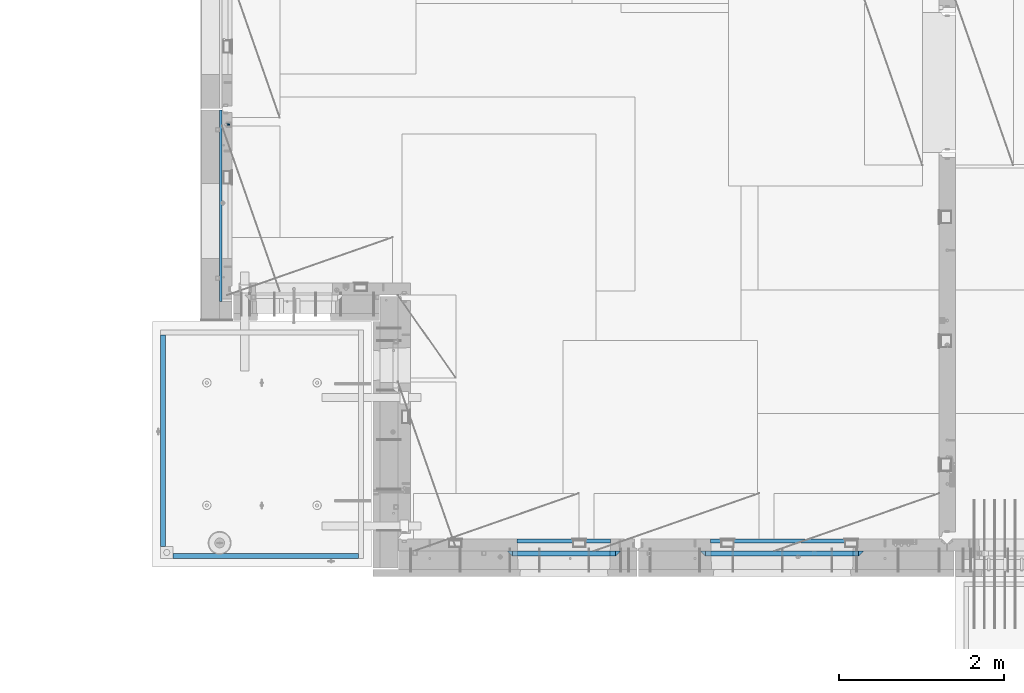
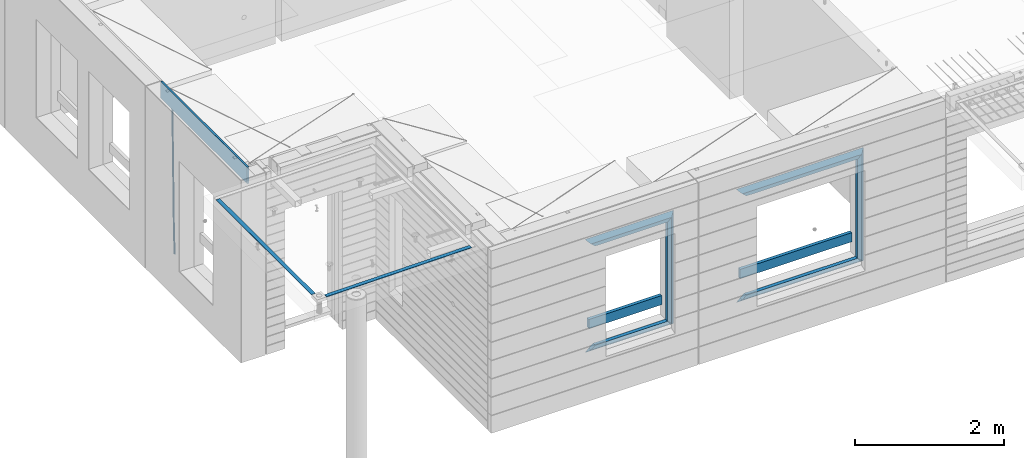
# One storey, part 92 of 349: 18 beams, 4 elements without a shape of their own.
"""IFC2X3 building model written with IfcOpenShell, lengths in millimetres."""

from ifc_helpers import new_model, si_unit, frame, origin_with_axes, place, context, subcontext, project, spatial, faceted_brep, material, type_object, element, aggregate, save


model = new_model("IFC2X3")

# Units and contexts
model_context = context("Model", 3, precision=1e-05, world=origin_with_axes())
body_context = subcontext(model_context, "Body", "Model", "MODEL_VIEW")
ifc_project = project(units=[si_unit("LENGTHUNIT", "METRE", prefix="MILLI"), si_unit("AREAUNIT", "SQUARE_METRE"), si_unit("VOLUMEUNIT", "CUBIC_METRE"), si_unit("MASSUNIT", "GRAM", prefix="KILO"), si_unit("TIMEUNIT", "SECOND"), si_unit("PLANEANGLEUNIT", "RADIAN"), si_unit("SOLIDANGLEUNIT", "STERADIAN"), si_unit("THERMODYNAMICTEMPERATUREUNIT", "DEGREE_CELSIUS"), si_unit("LUMINOUSINTENSITYUNIT", "LUMEN")], contexts=[model_context])

# Site, building, storey
site_placement = place(None, origin_with_axes())
site = spatial("IfcSite", under=ifc_project, at=site_placement, CompositionType="ELEMENT")
building_placement = place(site_placement, origin_with_axes())
building = spatial("IfcBuilding", under=site, at=building_placement, CompositionType="ELEMENT")
storey_placement = place(building_placement, origin_with_axes())
storey = spatial("IfcBuildingStorey", under=building, at=storey_placement, Name="4", CompositionType="ELEMENT", Elevation=0.0)

# Assembly, beam
assembly_1_placement = place(storey_placement, origin_with_axes())
assembly_1 = element("IfcElementAssembly", 1, at=assembly_1_placement, inside=storey, AssemblyPlace="NOTDEFINED", PredefinedType="REINFORCEMENT_UNIT")
ifc_material_1 = material()
beam_type_1 = type_object("IfcBeamType", Name="D20", PredefinedType="NOTDEFINED")
beam_1_placement = place(assembly_1_placement, frame((7964.99972837123, 13015.0021274634, 90990.0), z_axis=(-0.999642804636942, -0.000205726999925762, -0.0267249099902983), x_axis=(-0.0267249099948371, 4.30000201934385e-08, 0.999642825806181)))
beam_1 = element("IfcBeam", 2, at=beam_1_placement, type_object=beam_type_1, material=ifc_material_1, Name="JM20", ObjectType="D20", context=body_context, shape_type="Brep", body=[
    faceted_brep([(0.0, -10.0, 0.0), (-4.19531716033816e-08, -7.07106781186667, -7.07106781187031), (60.4266690400545, -7.0710677960451, -7.07106780570757), (60.4266690441291, -9.99999998418934, 6.15546014159918e-09), (0.0, 0.0, -10.0), (60.426669036824, 1.58106558956206e-08, -9.99999999384454), (4.196772351861e-08, 7.07106781186303, -7.07106781186667), (60.4266690363438, 7.07106782768096, -7.07106780570757), (0.0, 10.0, 0.0), (60.4266690388904, 10.0000000158179, 6.15182216279209e-09), (4.196772351861e-08, 7.07106781185939, 7.07106781185939), (60.4266690429649, 7.07106782768096, 7.07106781802577), (0.0, 0.0, 10.0), (60.4266690461809, 1.58179318532348e-08, 10.0000000061555), (-4.19531716033816e-08, -7.07106781187031, 7.07106781185939), (60.4266690466611, -7.07106779605238, 7.07106781802213), (61.0378400410118, -7.07106779588503, -7.07106780564936), (60.991799419251, -9.99999998403655, 6.21366780251265e-09), (61.0569027789461, 1.5985278878361e-08, -9.99999999378269), (61.0378209396877, 7.07106782784831, -7.07106780564936), (60.9917724058905, 10.0000000159635, 6.21366780251265e-09), (60.9457317841297, 7.07106782781193, 7.0710678180767), (60.9266690461809, 1.59488990902901e-08, 10.0000000062028), (60.9457508854539, -7.07106779591413, 7.0710678180767), (61.6489592143771, -7.07106614513759, -7.06310863441468), (61.5568818710308, -9.9999984576425, 0.00735959856683621), (61.6870830769039, 1.71821739058942e-06, -9.99179257185824), (61.6489210170112, 7.07106947854481, -7.06310888312146), (61.556827851804, 10.0000015422847, 0.00735924683976918), (61.4647505084577, 7.07106922979438, 7.07782747982128), (61.4266266459163, 1.36643211590126e-06, 10.0065114172685), (61.464788705809, -7.07106639389531, 7.07782772852806), (176.543135720174, -7.07075579406956, -5.56673531796696), (176.451058376813, -9.99968810657447, 1.50373291501455), (176.581259582701, 0.000312069292704109, -8.49541925541052), (176.543097522794, 7.07137982961285, -5.56673556667374), (176.451004357587, 10.00031189336, 1.50373256329476), (176.35892701424, 7.07137958085514, 8.57420079627263), (176.320803151699, 0.000311717507429421, 11.5028847337162), (176.358965211621, -7.07075604281999, 8.57420104497578), (177.098753836006, -7.07075429323595, -5.55949898843028), (176.98362511232, -9.99968666800123, 1.510669025065), (177.146421932586, 0.000313595905026887, -8.48805862247536), (177.098706077581, 7.07138133041735, -5.55949936166144), (176.983557571715, 10.0003133318824, 1.51066849724157), (176.868428848029, 7.07138095712435, 8.58083651073321), (176.820760751449, 0.000313067976094317, 11.5093961447819), (176.868476606425, -7.07075466652896, 8.58083688396073), (177.654312950661, -7.07075204110879, -5.54863964998367), (177.516135294456, -9.99968450931192, 1.52107783331303), (177.711524267797, 0.000315886711177882, -8.47701274570863), (177.654255632195, 7.07138358250813, -5.54864021007961), (177.516054233929, 10.0003154905207, 1.5210770412159), (177.377876577739, 7.0713830223176, 8.59079452451624), (177.320665260588, 0.000315094497636892, 11.5191676202448), (177.377933896176, -7.07075260129932, 8.59079508461218), (299.436796249574, -7.07025836271714, -3.1681962331204), (299.298618593355, -9.99919083092027, 3.90152125031091), (299.494007566798, 0.000809565110102994, -6.09656932889993), (299.436738931283, 7.07187726089978, -3.16819679320906), (299.298537533061, 10.0008091689197, 3.90152045822106), (299.160359876842, 7.07187670072017, 10.9712379416487), (299.103148559603, 0.000808772889286047, 13.8996110374392), (299.160417195119, -7.07025892290039, 10.9712385017483), (299.98743051647, -7.07025613056248, -3.15743315966392), (299.971788958996, -9.99918809853989, 3.91467979818117), (299.993912075952, 0.000811591617093654, -6.08679785393178), (299.987423933868, 7.07187949325817, -3.1574327280432), (299.971753863239, 10.0008119014747, 3.91467990454839), (299.95611230444, 7.07187992653053, 10.9867922621015), (299.949630744944, 0.000812204350950196, 13.9161569563694), (299.956118887014, -7.07025569729012, 10.9867918304735), (300.538107039494, -7.07025785017686, -3.16575821840888), (300.644985195438, -9.99919020432935, 3.90450175465594), (300.493854948218, 0.000810030429420294, -6.09435592770024), (300.538151196495, 7.071877773491, -3.16575855385963), (300.645047642858, 10.0008097955724, 3.90450128024895), (300.751925798773, 7.07187744142357, 10.9747612533101), (300.796177890064, 0.000809560813650023, 13.9033589625978), (300.751881641787, -7.07025818224065, 10.9747615887682), (2293.36490490142, -7.07648090940347, -33.2930642912361), (2293.47178305736, -10.0054132635523, -26.2228043181785), (2293.32065281013, -0.00541302880083094, -36.2216620005347), (2293.36494905842, 7.06565471425711, -33.2930646266868), (2293.47184550477, 9.99458673634581, -26.2228047925819), (2293.57872366071, 7.06565438219332, -19.1525448195243), (2293.62297575199, -0.00541349841296324, -16.2239471102366), (2293.57867950371, -7.0764812414709, -19.1525444840736), (2294.0658245362, -7.07648309818615, -33.3036607065333), (2294.05312277409, -10.0054150789219, -26.2315929392535), (2294.10928714235, -0.00541549149056664, -36.2335844756526), (2294.15805078732, 7.06565223761572, -33.3050546393533), (2294.18355038921, 9.99458451388637, -26.2335642579346), (2294.17084862708, 7.06565253314329, -19.1614964906439), (2294.12738602093, -0.00541507354500936, -16.2315727215355), (2294.07862237596, -7.07648280265857, -19.1601025578348), (2294.76670261032, -7.08562269121467, -33.294332712383), (2294.63442802057, -10.0129954178956, -26.2238563411993), (2294.89787471293, -0.0156988342423574, -36.2230891548279), (2294.95110548967, 7.05531064255774, -33.2944998654275), (2294.89521307347, 9.98530428734011, -26.2240927312887), (2294.76293848372, 7.0579315606592, -19.1536163601049), (2294.63176638114, -0.0119922963167483, -16.2248599176673), (2294.57853560438, -7.08300177311321, -19.1534492070678), (2316.52657204497, -7.36937582653991, -33.0047303660212), (2316.39429745522, -10.2967485532172, -25.9342539948302), (2316.65774414754, -0.299451969567599, -35.9334868084661), (2316.7109749243, 6.7715575072325, -33.0048975190657), (2316.65508250811, 9.70155115201487, -25.9344903849269), (2316.52280791836, 6.7741784253376, -18.8640140137468), (2316.39163581574, -0.295745431634714, -15.9352575713092), (2316.33840503903, -7.36675490843481, -18.863846860706), (2317.16202064224, -7.37766220584308, -32.9962731735213), (2317.05438744847, -10.3053562613532, -25.9254688497131), (2317.23607125619, -0.306993473008333, -35.925789846493), (2317.23316144495, 6.76474808850253, -32.9979477328052), (2317.15499573652, 9.6950321815566, -25.9278370341635), (2317.04736254275, 6.7673381260538, -18.8570327103698), (2316.97331192881, -0.303330606784584, -15.9275160373909), (2316.97622174003, -7.37507216829545, -18.8553581510787), (2317.79752306276, -7.37578610372293, -32.9880110666527), (2317.71453320107, -10.3033876998124, -25.9168792378296), (2317.81444760226, -0.305295583297266, -35.918287695793), (2317.75539265381, 6.76628640723357, -32.9911928173897), (2317.65495180529, 9.69652304524061, -25.9213789128698), (2317.5719619436, 6.76892144914746, -18.8502470840467), (2317.55503740412, -0.301569071270933, -15.9199704549137), (2317.61409235255, -7.3731510618054, -18.847065333317), (2417.8183084176, -7.07752398473531, -31.6906369377139), (2417.73531855589, -10.0051255808248, -24.6195051088798), (2417.83523295709, -0.007033464313281, -34.6209135668432), (2417.77617800863, 7.06454852621755, -31.6938186884508), (2417.67573716014, 9.99478516423187, -24.6240047839383), (2417.59274729842, 7.06718356813872, -17.5528729551006), (2417.57582275895, -0.00330695228694822, -14.6225963259749), (2417.6348777074, -7.07488894281778, -17.5496912043673)], [[[0, 1, 2, 3]], [[1, 4, 5, 2]], [[4, 6, 7, 5]], [[6, 8, 9, 7]], [[8, 10, 11, 9]], [[10, 12, 13, 11]], [[12, 14, 15, 13]], [[14, 0, 3, 15]], [[14, 12, 10, 8, 6, 4, 1, 0]], [[3, 2, 16, 17]], [[2, 5, 18, 16]], [[5, 7, 19, 18]], [[7, 9, 20, 19]], [[9, 11, 21, 20]], [[11, 13, 22, 21]], [[13, 15, 23, 22]], [[15, 3, 17, 23]], [[17, 16, 24, 25]], [[16, 18, 26, 24]], [[18, 19, 27, 26]], [[19, 20, 28, 27]], [[20, 21, 29, 28]], [[21, 22, 30, 29]], [[22, 23, 31, 30]], [[23, 17, 25, 31]], [[25, 24, 32, 33]], [[24, 26, 34, 32]], [[26, 27, 35, 34]], [[27, 28, 36, 35]], [[28, 29, 37, 36]], [[29, 30, 38, 37]], [[30, 31, 39, 38]], [[31, 25, 33, 39]], [[33, 32, 40, 41]], [[32, 34, 42, 40]], [[34, 35, 43, 42]], [[35, 36, 44, 43]], [[36, 37, 45, 44]], [[37, 38, 46, 45]], [[38, 39, 47, 46]], [[39, 33, 41, 47]], [[41, 40, 48, 49]], [[40, 42, 50, 48]], [[42, 43, 51, 50]], [[43, 44, 52, 51]], [[44, 45, 53, 52]], [[45, 46, 54, 53]], [[46, 47, 55, 54]], [[47, 41, 49, 55]], [[49, 48, 56, 57]], [[48, 50, 58, 56]], [[50, 51, 59, 58]], [[51, 52, 60, 59]], [[52, 53, 61, 60]], [[53, 54, 62, 61]], [[54, 55, 63, 62]], [[55, 49, 57, 63]], [[57, 56, 64, 65]], [[56, 58, 66, 64]], [[58, 59, 67, 66]], [[59, 60, 68, 67]], [[60, 61, 69, 68]], [[61, 62, 70, 69]], [[62, 63, 71, 70]], [[63, 57, 65, 71]], [[65, 64, 72, 73]], [[64, 66, 74, 72]], [[66, 67, 75, 74]], [[67, 68, 76, 75]], [[68, 69, 77, 76]], [[69, 70, 78, 77]], [[70, 71, 79, 78]], [[71, 65, 73, 79]], [[73, 72, 80, 81]], [[72, 74, 82, 80]], [[74, 75, 83, 82]], [[75, 76, 84, 83]], [[76, 77, 85, 84]], [[77, 78, 86, 85]], [[78, 79, 87, 86]], [[79, 73, 81, 87]], [[81, 80, 88, 89]], [[80, 82, 90, 88]], [[82, 83, 91, 90]], [[83, 84, 92, 91]], [[84, 85, 93, 92]], [[85, 86, 94, 93]], [[86, 87, 95, 94]], [[87, 81, 89, 95]], [[89, 88, 96, 97]], [[88, 90, 98, 96]], [[90, 91, 99, 98]], [[91, 92, 100, 99]], [[92, 93, 101, 100]], [[93, 94, 102, 101]], [[94, 95, 103, 102]], [[95, 89, 97, 103]], [[97, 96, 104, 105]], [[96, 98, 106, 104]], [[98, 99, 107, 106]], [[99, 100, 108, 107]], [[100, 101, 109, 108]], [[101, 102, 110, 109]], [[102, 103, 111, 110]], [[103, 97, 105, 111]], [[105, 104, 112, 113]], [[104, 106, 114, 112]], [[106, 107, 115, 114]], [[107, 108, 116, 115]], [[108, 109, 117, 116]], [[109, 110, 118, 117]], [[110, 111, 119, 118]], [[111, 105, 113, 119]], [[113, 112, 120, 121]], [[112, 114, 122, 120]], [[114, 115, 123, 122]], [[115, 116, 124, 123]], [[116, 117, 125, 124]], [[117, 118, 126, 125]], [[118, 119, 127, 126]], [[119, 113, 121, 127]], [[121, 120, 128, 129]], [[120, 122, 130, 128]], [[122, 123, 131, 130]], [[123, 124, 132, 131]], [[124, 125, 133, 132]], [[125, 126, 134, 133]], [[126, 127, 135, 134]], [[127, 121, 129, 135]], [[130, 131, 132, 133, 134, 135, 129, 128]]]),
])

assembly_2_placement = place(storey_placement, origin_with_axes())
assembly_2 = element("IfcElementAssembly", 3, at=assembly_2_placement, inside=storey, AssemblyPlace="NOTDEFINED", PredefinedType="REINFORCEMENT_UNIT")
ifc_material_2 = material(Name="TIMBER/T24")
beam_type_2 = type_object("IfcBeamType", PredefinedType="NOTDEFINED")
beam_2_placement = place(assembly_2_placement, frame((11453.0009023501, 7974.99972412935, 91685.0), z_axis=(0.0, 0.0, 1.0), x_axis=(1.0, 0.0, 0.0)))
beam_2 = element("IfcBeam", 4, at=beam_2_placement, type_object=beam_type_2, material=ifc_material_2, context=body_context, shape_type="Brep", body=[
    faceted_brep([(-3.63797880709171e-12, 24.9999999999964, -75.0), (-3.63797880709171e-12, 24.9999999999964, 75.0), (1130.0, 25.0, 75.0), (1130.0, 25.0, -75.0), (0.0, -25.0000000000073, 75.0), (1130.0, -25.0, 75.0), (0.0, -25.0000000000073, -75.0), (1130.0, -25.0, -75.0)], [[[0, 1, 2, 3]], [[1, 4, 5, 2]], [[4, 6, 7, 5]], [[6, 0, 3, 7]], [[5, 7, 3, 2]], [[6, 4, 1, 0]]]),
])

assembly_3_placement = place(storey_placement, origin_with_axes())
assembly_3 = element("IfcElementAssembly", 5, at=assembly_3_placement, inside=storey, AssemblyPlace="NOTDEFINED", PredefinedType="REINFORCEMENT_UNIT")
beam_3_placement = place(assembly_3_placement, frame((13795.0009023501, 7974.99972412935, 91685.0), z_axis=(0.0, 0.0, 1.0), x_axis=(1.0, 0.0, 0.0)))
beam_3 = element("IfcBeam", 6, at=beam_3_placement, type_object=beam_type_2, material=ifc_material_2, context=body_context, shape_type="Brep", body=[
    faceted_brep([(-3.63797880709171e-12, 24.9999999999964, -75.0), (-3.63797880709171e-12, 24.9999999999964, 75.0), (1730.0, 25.0, 75.0), (1730.0, 25.0, -75.0), (0.0, -25.0000000000073, 75.0), (1730.0, -25.0, 75.0), (0.0, -25.0000000000073, -75.0), (1730.0, -25.0, -75.0)], [[[0, 1, 2, 3]], [[1, 4, 5, 2]], [[4, 6, 7, 5]], [[6, 0, 3, 7]], [[5, 7, 3, 2]], [[6, 4, 1, 0]]]),
])

# Assembly, beams
assembly_4_placement = place(storey_placement, origin_with_axes())
assembly_4 = element("IfcElementAssembly", 7, at=assembly_4_placement, inside=storey, AssemblyPlace="NOTDEFINED", PredefinedType="REINFORCEMENT_UNIT")
ifc_material_3 = material(Name="CONCRETE/Concrete_Undefined")
beam_type_3 = type_object("IfcBeamType", PredefinedType="NOTDEFINED")
beam_4_placement = place(assembly_4_placement, frame((7164.89422591706, 10470.0076633258, 93701.6030105556), z_axis=(0.0, -1.17599999975856e-06, 0.999999999999309), x_axis=(4.13430000058061e-05, -0.999999999144687, -1.176000002514e-06)))
beam_4 = element("IfcBeam", 8, at=beam_4_placement, type_object=beam_type_3, material=ifc_material_3, context=body_context, shape_type="Brep", body=[
    faceted_brep([(2.5465851649642e-11, 29.9999999999982, -4.99999999998545), (-2.91038304567337e-11, 29.9999999999982, 5.0), (2560.00574992944, 30.0000000000009, 5.00000000001455), (2560.00574992944, 30.0, -5.0), (-2.5465851649642e-11, -30.0000000000018, 5.0), (2560.00574992944, -29.9999999999991, 5.00000000001455), (2.72848410531878e-11, -30.0000000000018, -4.99999999998545), (2560.00574992944, -30.0, -5.0)], [[[0, 1, 2, 3]], [[1, 4, 5, 2]], [[4, 6, 7, 5]], [[6, 0, 3, 7]], [[5, 7, 3, 2]], [[6, 4, 1, 0]]]),
])
beam_5_placement = place(assembly_4_placement, frame((9529.67128970205, 7789.99860988154, 93725.2790473986), z_axis=(-0.00918361699724776, 4.9999998721906e-09, 0.999957829700257), x_axis=(-0.999957829700102, 5.55999999934641e-07, -0.00918361699724765)))
beam_5 = element("IfcBeam", 9, at=beam_5_placement, type_object=beam_type_3, material=ifc_material_3, context=body_context, shape_type="Brep", body=[
    faceted_brep([(2.5465851649642e-11, 29.9999999999982, -4.99999999998545), (-2.91038304567337e-11, 29.9999999999982, 5.0), (2244.79868782777, 30.0, 5.00000000001455), (2244.79868782778, 30.0, -4.99999999995634), (-2.5465851649642e-11, -30.0000000000018, 5.0), (2244.79868782778, -30.0000000000009, 5.00000000001455), (2.72848410531878e-11, -30.0000000000018, -4.99999999998545), (2244.79868782778, -30.0, -4.9999999999709)], [[[0, 1, 2, 3]], [[1, 4, 5, 2]], [[4, 6, 7, 5]], [[6, 0, 3, 7]], [[5, 7, 3, 2]], [[6, 4, 1, 0]]]),
])
aggregate(assembly_4, [beam_4, beam_5])

# Beam
ifc_material_4 = material(Name="CONCRETE/C25/30")
beam_type_4 = type_object("IfcBeamType", PredefinedType="NOTDEFINED")
beam_6_placement = place(assembly_2_placement, frame((11393.0000473781, 7820.0, 93085.0), z_axis=(0.0, 0.0, -1.0), x_axis=(1.0, 0.0, 0.0)))
beam_6 = element("IfcBeam", 10, at=beam_6_placement, type_object=beam_type_4, material=ifc_material_4, Name="SK", context=body_context, shape_type="Brep", body=[
    faceted_brep([(1185.94632735287, -29.9999988381387, 24.0540541168593), (1184.32470579405, 29.9999988381387, 25.6756756756804), (65.6760571454033, 29.9999988381387, 25.6756756756804), (64.0544355865859, -29.9999988381387, 24.0540541168593), (65.6760571454033, 29.9999988381387, 26.2937632551475), (64.0544355865859, -29.9999988381387, 24.9038019193104), (0.0, 30.0, -30.0), (0.0, -30.0, -30.0), (1250.00038146973, -29.9999988381387, -30.0), (1185.94632735287, -29.9999988381387, 24.9034749452549), (1184.32470579405, 29.9999988381387, 26.2934362810629), (1250.00038146973, 29.9999988381387, -30.0)], [[[0, 1, 2, 3]], [[3, 2, 4, 5]], [[5, 4, 6, 7]], [[0, 3, 5, 7, 8, 9]], [[1, 0, 9, 10]], [[6, 4, 2, 1, 10, 11]], [[7, 6, 11, 8]], [[8, 11, 10, 9]]]),
])

beam_7_placement = place(assembly_2_placement, frame((11333.0000473781, 7820.0, 93145.0), z_axis=(0.0, 0.0, -1.0), x_axis=(1.0, 0.0, 0.0)))
beam_7 = element("IfcBeam", 11, at=beam_7_placement, type_object=beam_type_4, material=ifc_material_4, Name="SK", context=body_context, shape_type="Brep", body=[
    faceted_brep([(60.0000000000073, 30.0, 30.0), (0.0, -30.0, -30.0), (60.0000000000073, -30.0, 30.0), (1370.00038146973, -30.0, -30.0), (1310.0003814697, -30.0, 30.0), (1310.0003814697, 30.0, 30.0)], [[[0, 1, 2]], [[2, 1, 3, 4]], [[0, 2, 4, 5]], [[1, 0, 5, 3]], [[3, 5, 4]]]),
])

beam_8_placement = place(assembly_2_placement, frame((12673.0004288479, 7820.0, 93175.0), z_axis=(-1.0, 3.00000001838171e-08, 0.0), x_axis=(0.0, 0.0, -1.0)))
beam_8 = element("IfcBeam", 12, at=beam_8_placement, type_object=beam_type_4, material=ifc_material_4, Name="SK", context=body_context, shape_type="Brep", body=[
    faceted_brep([(60.0000000000073, 30.0, 30.0), (0.0, -30.0, -30.0), (60.0000000000073, -30.0, 30.0), (1855.0, -30.0, -30.0), (1795.00000000001, -30.0, 30.0), (1795.00000000001, 30.0, 30.0)], [[[0, 1, 2]], [[3, 4, 2, 1]], [[4, 5, 0, 2]], [[5, 3, 1, 0]], [[4, 3, 5]]]),
])

beam_9_placement = place(assembly_2_placement, frame((12703.0004288479, 7820.0, 91350.0), z_axis=(0.0, 0.0, 1.0), x_axis=(-1.0, 3.00000001838171e-08, 0.0)))
beam_9 = element("IfcBeam", 13, at=beam_9_placement, type_object=beam_type_4, material=ifc_material_4, Name="SK", context=body_context, shape_type="Brep", body=[
    faceted_brep([(1370.00038146973, -30.0, -30.0), (1310.0003814697, 30.0, 30.0), (1310.0003814697, -30.0, 30.0), (0.0, -30.0, -30.0), (60.0000000000073, 30.0, 30.0), (60.0000000000073, -30.0, 30.0)], [[[0, 1, 2]], [[3, 4, 1, 0]], [[4, 5, 2, 1]], [[5, 3, 0, 2]], [[4, 3, 5]]]),
])

beam_10_placement = place(assembly_2_placement, frame((12643.0004288479, 7820.0, 91410.0), z_axis=(0.0, 0.0, 1.0), x_axis=(-1.0, 3.00000001838171e-08, 0.0)))
beam_10 = element("IfcBeam", 14, at=beam_10_placement, type_object=beam_type_4, material=ifc_material_4, Name="SK", context=body_context, shape_type="Brep", body=[
    faceted_brep([(1185.94594588314, -29.9999988381387, 24.0540541168593), (1184.32432432432, 29.9999988381387, 25.6756756756804), (65.6756756756768, 30.0, 25.6756756756804), (64.0540540540533, -30.0, 24.0540540540533), (1185.94594588314, -29.9999988381387, 24.9038019193104), (1184.32432432432, 29.9999988381387, 26.2937632551329), (1250.00038146973, -29.9999988381387, -30.0), (1250.00038146973, 29.9999988381387, -30.0), (0.0, -30.0, -30.0), (0.0, 30.0, -30.0), (65.6756756756768, 30.0, 26.293436281092), (64.0540540540533, -30.0, 24.9034748914419)], [[[0, 1, 2, 3]], [[1, 0, 4, 5]], [[4, 6, 7, 5]], [[8, 9, 7, 6]], [[2, 1, 5, 7, 9, 10]], [[3, 2, 10, 11]], [[6, 4, 0, 3, 11, 8]], [[8, 11, 10, 9]]]),
])

beam_11_placement = place(assembly_3_placement, frame((13675.0004364773, 7820.0, 93145.0), z_axis=(0.0, 0.0, -1.0), x_axis=(1.0, 0.0, 0.0)))
beam_11 = element("IfcBeam", 15, at=beam_11_placement, type_object=beam_type_4, material=ifc_material_4, Name="SK", context=body_context, shape_type="Brep", body=[
    faceted_brep([(60.0000000000073, 30.0, 30.0), (0.0, -30.0, -30.0), (60.0000000000073, -30.0, 30.0), (1969.99980926514, -30.0, -30.0), (1909.99980926512, -30.0, 30.0), (1909.99980926512, 30.0, 30.0)], [[[0, 1, 2]], [[2, 1, 3, 4]], [[0, 2, 4, 5]], [[1, 0, 5, 3]], [[4, 3, 5]]]),
])

beam_12_placement = place(assembly_3_placement, frame((13735.0004364773, 7820.0, 93085.0), z_axis=(0.0, 0.0, -1.0), x_axis=(1.0, 0.0, 0.0)))
beam_12 = element("IfcBeam", 16, at=beam_12_placement, type_object=beam_type_4, material=ifc_material_4, Name="SK", context=body_context, shape_type="Brep", body=[
    faceted_brep([(1785.94575521108, -30.0, 24.0540540540533), (1784.32413358946, 30.0, 25.6756756756804), (65.6754849408117, 30.0, 25.6756756756804), (64.05386331919, -30.0, 24.0540540540533), (65.6754849408117, 30.0, 26.2932727940788), (64.05386331919, -30.0, 24.9033114044141), (0.0, -30.0, -30.0), (0.0, 30.0, -30.0), (1849.99980926514, -30.0, -30.0), (1785.94575521108, -30.0, 24.9034748914273), (1784.32413358946, 30.0, 26.293436281092), (1849.99980926514, 30.0, -30.0)], [[[0, 1, 2, 3]], [[3, 2, 4, 5]], [[6, 5, 4, 7]], [[0, 3, 5, 6, 8, 9]], [[1, 0, 9, 10]], [[7, 4, 2, 1, 10, 11]], [[6, 7, 11, 8]], [[10, 9, 8, 11]]]),
])

beam_13_placement = place(assembly_3_placement, frame((15615.0002457424, 7820.0, 93175.0), z_axis=(-1.0, 3.00000001838171e-08, 0.0), x_axis=(0.0, 0.0, -1.0)))
beam_13 = element("IfcBeam", 17, at=beam_13_placement, type_object=beam_type_4, material=ifc_material_4, Name="SK", context=body_context, shape_type="Brep", body=[
    faceted_brep([(60.0000000000073, 30.0, 30.0), (0.0, -30.0, -30.0), (60.0000000000073, -30.0, 30.0), (1855.0, -30.0, -30.0), (1795.00000000001, -30.0, 30.0), (1795.00000000001, 30.0, 30.0)], [[[0, 1, 2]], [[3, 4, 2, 1]], [[4, 5, 0, 2]], [[5, 3, 1, 0]], [[4, 3, 5]]]),
])

beam_14_placement = place(assembly_3_placement, frame((15645.0002457424, 7820.0, 91350.0), z_axis=(0.0, 0.0, 1.0), x_axis=(-1.0, 3.00000001838171e-08, 0.0)))
beam_14 = element("IfcBeam", 18, at=beam_14_placement, type_object=beam_type_4, material=ifc_material_4, Name="SK", context=body_context, shape_type="Brep", body=[
    faceted_brep([(1909.99980926512, -30.0, 30.0), (1969.99980926514, -30.0, -30.0), (1909.99980926512, 30.0, 30.0), (0.0, -30.0, -30.0), (60.0000000000073, 30.0, 30.0), (60.0000000000073, -30.0, 30.0)], [[[0, 1, 2]], [[3, 4, 2, 1]], [[4, 5, 0, 2]], [[5, 3, 1, 0]], [[4, 3, 5]]]),
])

beam_15_placement = place(assembly_3_placement, frame((15585.0002457424, 7820.0, 91410.0), z_axis=(0.0, 0.0, 1.0), x_axis=(-1.0, 3.00000001838171e-08, 0.0)))
beam_15 = element("IfcBeam", 19, at=beam_15_placement, type_object=beam_type_4, material=ifc_material_4, Name="SK", context=body_context, shape_type="Brep", body=[
    faceted_brep([(1785.94594594595, -30.0, 24.0540540540533), (1784.32432432433, 30.0, 25.6756756756804), (65.6756756756768, 30.0, 25.6756756756804), (64.0540540540533, -30.0, 24.0540540540533), (1785.94594594595, -30.0, 24.9033114043996), (1784.32432432433, 30.0, 26.2932727940788), (1849.99980926514, -30.0, -30.0), (1849.99980926514, 30.0, -30.0), (0.0, -30.0, -30.0), (0.0, 30.0, -30.0), (65.6756756756768, 30.0, 26.293436281092), (64.0540540540533, -30.0, 24.9034748914419)], [[[0, 1, 2, 3]], [[1, 0, 4, 5]], [[6, 7, 5, 4]], [[8, 9, 7, 6]], [[2, 1, 5, 7, 9, 10]], [[3, 2, 10, 11]], [[6, 4, 0, 3, 11, 8]], [[8, 11, 10, 9]]]),
])

beam_type_5 = type_object("IfcBeamType", PredefinedType="NOTDEFINED")
beam_16_placement = place(assembly_2_placement, frame((12608.0004288479, 7820.0, 93115.0), z_axis=(-1.0, 3.00000001838171e-08, 0.0), x_axis=(0.0, 0.0, -1.0)))
beam_16 = element("IfcBeam", 20, at=beam_16_placement, type_object=beam_type_5, material=ifc_material_4, Name="SK", context=body_context, shape_type="Brep", body=[
    faceted_brep([(0.0, -30.0, -35.0), (54.9034748914273, -30.0, 29.0540540540533), (56.2934362811066, 30.0, 30.6756756756768), (0.0, 30.0, -35.0), (1735.0, -30.0, -35.0), (1680.09652510857, -30.0, 29.0540540540533), (1678.70656371891, 30.0, 30.6756756756768), (1735.0, 30.0, -35.0)], [[[0, 1, 2, 3]], [[1, 0, 4, 5]], [[2, 1, 5, 6]], [[3, 2, 6, 7]], [[7, 4, 0, 3]], [[4, 7, 6, 5]]]),
])

aggregate(assembly_2, [beam_2, beam_6, beam_7, beam_8, beam_16, beam_9, beam_10])

beam_17_placement = place(assembly_3_placement, frame((15550.0002457424, 7820.0, 93115.0), z_axis=(-1.0, 3.00000001838171e-08, 0.0), x_axis=(0.0, 0.0, -1.0)))
beam_17 = element("IfcBeam", 21, at=beam_17_placement, type_object=beam_type_5, material=ifc_material_4, Name="SK", context=body_context, shape_type="Brep", body=[
    faceted_brep([(0.0, -30.0, -35.0), (54.9034748914273, -30.0, 29.0540540540533), (56.2934362811066, 30.0, 30.6756756756768), (0.0, 30.0, -35.0), (1735.0, -30.0, -35.0), (1680.09652510857, -30.0, 29.0540540540533), (1678.70656371891, 30.0, 30.6756756756768), (1735.0, 30.0, -35.0)], [[[0, 1, 2, 3]], [[1, 0, 4, 5]], [[2, 1, 5, 6]], [[3, 2, 6, 7]], [[7, 4, 0, 3]], [[4, 7, 6, 5]]]),
])

aggregate(assembly_3, [beam_11, beam_12, beam_13, beam_17, beam_14, beam_15, beam_3])

beam_type_6 = type_object("IfcBeamType", Name="270X30", PredefinedType="NOTDEFINED")
beam_18_placement = place(assembly_1_placement, frame((7864.99972556029, 13195.0003943318, 93605.0), z_axis=(0.0, 0.0, 1.0), x_axis=(0.0, -1.0, 0.0)))
beam_18 = element("IfcBeam", 22, at=beam_18_placement, type_object=beam_type_6, material=ifc_material_4, ObjectType="270X30", context=body_context, shape_type="Brep", body=[
    faceted_brep([(0.0, 15.0, -135.0), (0.0, 15.0, 135.0), (2320.00069431986, 15.0000000000009, 135.0), (2320.00069431986, 15.0000000000009, -135.0), (0.0, -15.0, 135.0), (2320.00069431986, -14.9999999999991, 135.0), (0.0, -15.0, -135.0), (2320.00069431986, -14.9999999999991, -135.0)], [[[0, 1, 2, 3]], [[1, 4, 5, 2]], [[4, 6, 7, 5]], [[6, 0, 3, 7]], [[5, 7, 3, 2]], [[6, 4, 1, 0]]]),
])

aggregate(assembly_1, [beam_1, beam_18])

save(model, "model.ifc")
